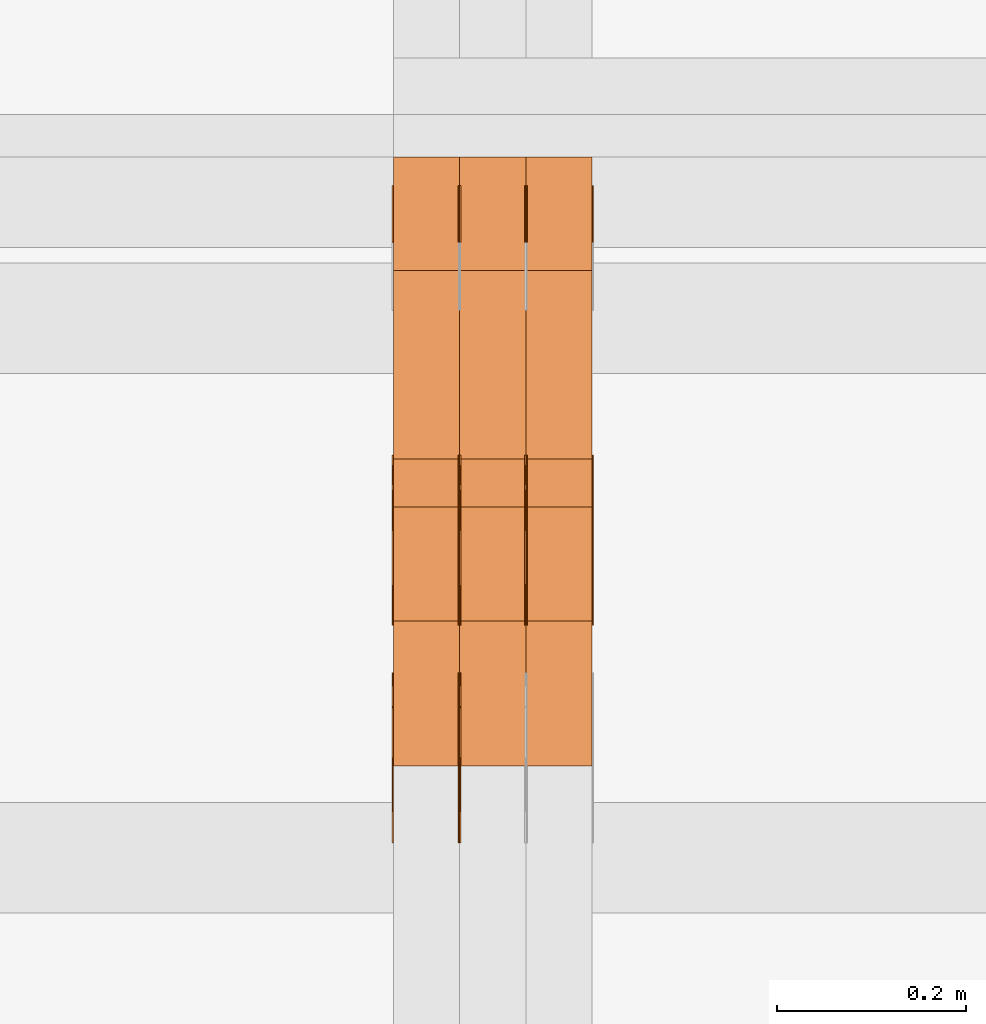
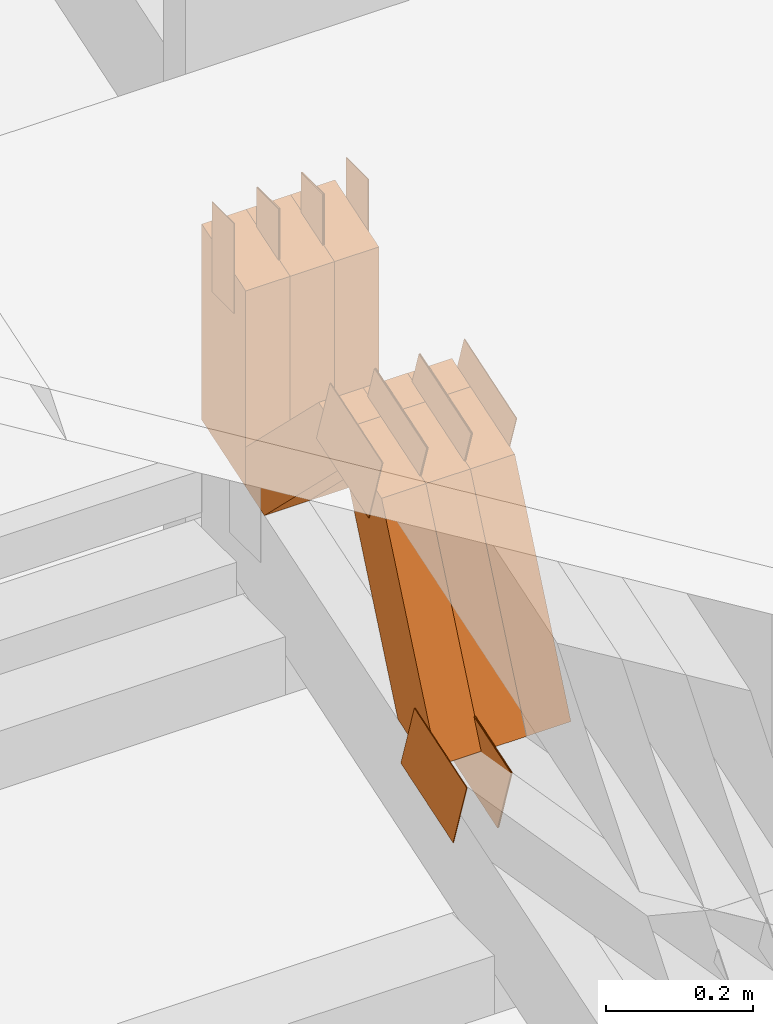
# One storey, part 160 of 385: 24 proxies.
"""IFC2X3 building model written with IfcOpenShell, lengths in millimetres."""

from ifc_helpers import new_model, entity, si_unit, converted_unit, derived_unit, direction, frame, origin, origin_2d_with_axis, place, context, subcontext, project, spatial, polyline, rectangle, outline, extrude, source, transform, mapped, material, type_object, type_shapes, element, save


model = new_model("IFC2X3")

# Units and contexts
model_context = context("Model", 3, precision=0.01, world=origin(), true_north=direction((6.12303176911189e-17, 1.0)))
body_context = subcontext(model_context, "Body", "Model", "MODEL_VIEW")
ifc_project = project(units=[si_unit("LENGTHUNIT", "METRE", prefix="MILLI"), si_unit("AREAUNIT", "SQUARE_METRE"), si_unit("VOLUMEUNIT", "CUBIC_METRE"), converted_unit("PLANEANGLEUNIT", "DEGREE", entity("IfcRatioMeasure", 0.0174532925199433), si_unit("PLANEANGLEUNIT", "RADIAN"), dimensions=[0, 0, 0, 0, 0, 0, 0]), si_unit("MASSUNIT", "GRAM", prefix="KILO"), derived_unit("MASSDENSITYUNIT", [(si_unit("MASSUNIT", "GRAM", prefix="KILO"), 1), (si_unit("LENGTHUNIT", "METRE"), -3)]), si_unit("TIMEUNIT", "SECOND"), si_unit("FREQUENCYUNIT", "HERTZ"), si_unit("THERMODYNAMICTEMPERATUREUNIT", "DEGREE_CELSIUS"), derived_unit("THERMALTRANSMITTANCEUNIT", [(si_unit("MASSUNIT", "GRAM", prefix="KILO"), 1), (si_unit("THERMODYNAMICTEMPERATUREUNIT", "KELVIN"), -1), (si_unit("TIMEUNIT", "SECOND"), -3)]), derived_unit("VOLUMETRICFLOWRATEUNIT", [(si_unit("LENGTHUNIT", "METRE"), 3), (si_unit("TIMEUNIT", "SECOND"), -1)]), si_unit("ELECTRICCURRENTUNIT", "AMPERE"), si_unit("ELECTRICVOLTAGEUNIT", "VOLT"), si_unit("POWERUNIT", "WATT"), si_unit("FORCEUNIT", "NEWTON", prefix="KILO"), si_unit("ILLUMINANCEUNIT", "LUX"), si_unit("LUMINOUSFLUXUNIT", "LUMEN"), si_unit("LUMINOUSINTENSITYUNIT", "CANDELA"), derived_unit("USERDEFINED", [(si_unit("MASSUNIT", "GRAM", prefix="KILO"), -1), (si_unit("LENGTHUNIT", "METRE"), -2), (si_unit("TIMEUNIT", "SECOND"), 3), (si_unit("LUMINOUSFLUXUNIT", "LUMEN"), 1)]), derived_unit("LINEARVELOCITYUNIT", [(si_unit("LENGTHUNIT", "METRE"), 1), (si_unit("TIMEUNIT", "SECOND"), -1)]), si_unit("PRESSUREUNIT", "PASCAL"), derived_unit("USERDEFINED", [(si_unit("LENGTHUNIT", "METRE"), -2), (si_unit("MASSUNIT", "GRAM", prefix="KILO"), 1), (si_unit("TIMEUNIT", "SECOND"), -2)])], contexts=[model_context])

# Site, building, storey
site_placement = place(None, origin())
site = spatial("IfcSite", under=ifc_project, at=site_placement, CompositionType="ELEMENT")
building_placement = place(site_placement, origin())
building = spatial("IfcBuilding", under=site, at=building_placement, CompositionType="ELEMENT")
storey_placement = place(building_placement, origin())
storey = spatial("IfcBuildingStorey", under=building, at=storey_placement, Name="Default", CompositionType="ELEMENT", Elevation=0.0)

# Proxies
ifc_material_1 = material(Name="IfcSurfaceStyle #380787")
building_element_proxy_type_1 = type_object("IfcBuildingElementProxyType", PredefinedType="NOTDEFINED", material=ifc_material_1)
shared_shape_1 = source(origin(), body_context, "Body", "SweptSolid", [
    extrude(outline(polyline([(-75.0003398116828, -59.9998507501386), (75.0003249421766, -59.9998507501386), (75.0003398116837, 59.9998507501387), (-75.0003249421775, 59.9998507501387), (-75.0003398116828, -59.9998507501386)])), frame((75.0003398116837, 60.0000773549637, 0.0), z_axis=(0.0, 0.0, 1.0), x_axis=(-1.0, 0.0, 0.0)), (0.0, 0.0, 1.0), 1.29999999999999),
])
type_shapes(building_element_proxy_type_1, [shared_shape_1])
proxy_1_placement = place(building_placement, frame((30245.0, 13054.73046875, 3417.8388671875), z_axis=(-1.0, 0.0, 0.0), x_axis=(0.0, 0.951056516295124, 0.309016994375039)))
element("IfcBuildingElementProxy", 1, at=proxy_1_placement, inside=storey, type_object=building_element_proxy_type_1, material=ifc_material_1, context=body_context, shape_type="MappedRepresentation", body=[
    mapped(shared_shape_1, transform((0.0, 0.0, 0.0), scale=1.0)),
])
ifc_material_2 = material(Name="IfcSurfaceStyle #380730")
building_element_proxy_type_2 = type_object("IfcBuildingElementProxyType", PredefinedType="NOTDEFINED", material=ifc_material_2)
shared_shape_2 = source(origin(), body_context, "Body", "SweptSolid", [
    extrude(outline(polyline([(-75.0003398116828, -59.9998507501386), (75.0003249421766, -59.9998507501386), (75.0003398116837, 59.9998507501387), (-75.0003249421775, 59.9998507501387), (-75.0003398116828, -59.9998507501386)])), frame((75.0003398116837, 60.0000773549637, 0.0), z_axis=(0.0, 0.0, 1.0), x_axis=(-1.0, 0.0, 0.0)), (0.0, 0.0, 1.0), 1.29999999999999),
])
type_shapes(building_element_proxy_type_2, [shared_shape_2])
proxy_2_placement = place(building_placement, frame((30246.3, 13054.73046875, 3417.8388671875), z_axis=(-1.0, 0.0, 0.0), x_axis=(0.0, 0.951056516295124, 0.309016994375039)))
element("IfcBuildingElementProxy", 2, at=proxy_2_placement, inside=storey, type_object=building_element_proxy_type_2, material=ifc_material_2, context=body_context, shape_type="MappedRepresentation", body=[
    mapped(shared_shape_2, transform((0.0, 0.0, 0.0), scale=1.0)),
])
ifc_material_3 = material(Name="IfcSurfaceStyle #380673")
building_element_proxy_type_3 = type_object("IfcBuildingElementProxyType", PredefinedType="NOTDEFINED", material=ifc_material_3)
shared_shape_3 = source(origin(), body_context, "Body", "SweptSolid", [
    extrude(outline(polyline([(-75.0003398116828, -59.9998507501386), (75.0003249421766, -59.9998507501386), (75.0003398116837, 59.9998507501387), (-75.0003249421775, 59.9998507501387), (-75.0003398116828, -59.9998507501386)])), frame((75.0003398116837, 60.0000773549637, 0.0), z_axis=(0.0, 0.0, 1.0), x_axis=(-1.0, 0.0, 0.0)), (0.0, 0.0, 1.0), 1.29999999999999),
])
type_shapes(building_element_proxy_type_3, [shared_shape_3])
proxy_3_placement = place(building_placement, frame((30175.0, 13054.73046875, 3417.8388671875), z_axis=(-1.0, 0.0, 0.0), x_axis=(0.0, 0.951056516295124, 0.309016994375039)))
element("IfcBuildingElementProxy", 3, at=proxy_3_placement, inside=storey, type_object=building_element_proxy_type_3, material=ifc_material_3, context=body_context, shape_type="MappedRepresentation", body=[
    mapped(shared_shape_3, transform((0.0, 0.0, 0.0), scale=1.0)),
])
ifc_material_4 = material(Name="IfcSurfaceStyle #373092")
building_element_proxy_type_4 = type_object("IfcBuildingElementProxyType", PredefinedType="NOTDEFINED", material=ifc_material_4)
shared_shape_4 = source(origin(), body_context, "Body", "SweptSolid", [
    extrude(outline(polyline([(-74.999875428623, -60.0000016373506), (74.9998605591059, -60.0000016373506), (74.9998754286239, 60.0000016373506), (-74.9998605591068, 60.0000016373506), (-74.999875428623, -60.0000016373506)])), frame((75.0002691827262, 60.0000190504561, 0.0), z_axis=(0.0, 0.0, 1.0), x_axis=(-1.0, 0.0, 0.0)), (0.0, 0.0, 1.0), 1.3),
])
type_shapes(building_element_proxy_type_4, [shared_shape_4])
proxy_4_placement = place(building_placement, frame((30386.3, 13285.0865109705, 3819.37496637467), z_axis=(-1.0, 0.0, 0.0), x_axis=(0.0, 0.951056516295154, 0.309016994374948)))
element("IfcBuildingElementProxy", 4, at=proxy_4_placement, inside=storey, type_object=building_element_proxy_type_4, material=ifc_material_4, context=body_context, shape_type="MappedRepresentation", body=[
    mapped(shared_shape_4, transform((0.0, 0.0, 0.0), scale=1.0)),
])
ifc_material_5 = material(Name="IfcSurfaceStyle #373035")
building_element_proxy_type_5 = type_object("IfcBuildingElementProxyType", PredefinedType="NOTDEFINED", material=ifc_material_5)
shared_shape_5 = source(origin(), body_context, "Body", "SweptSolid", [
    extrude(outline(polyline([(-74.999875428623, -60.0000016373506), (74.9998605591059, -60.0000016373506), (74.9998754286239, 60.0000016373506), (-74.9998605591068, 60.0000016373506), (-74.999875428623, -60.0000016373506)])), frame((75.0002691827262, 60.0000190504561, 0.0), z_axis=(0.0, 0.0, 1.0), x_axis=(-1.0, 0.0, 0.0)), (0.0, 0.0, 1.0), 1.3),
])
type_shapes(building_element_proxy_type_5, [shared_shape_5])
proxy_5_placement = place(building_placement, frame((30315.0, 13285.0865109705, 3819.37496637467), z_axis=(-1.0, 0.0, 0.0), x_axis=(0.0, 0.951056516295154, 0.309016994374948)))
element("IfcBuildingElementProxy", 5, at=proxy_5_placement, inside=storey, type_object=building_element_proxy_type_5, material=ifc_material_5, context=body_context, shape_type="MappedRepresentation", body=[
    mapped(shared_shape_5, transform((0.0, 0.0, 0.0), scale=1.0)),
])
ifc_material_6 = material(Name="IfcSurfaceStyle #372978")
building_element_proxy_type_6 = type_object("IfcBuildingElementProxyType", PredefinedType="NOTDEFINED", material=ifc_material_6)
shared_shape_6 = source(origin(), body_context, "Body", "SweptSolid", [
    extrude(outline(polyline([(-74.999875428623, -60.0000016373506), (74.9998605591059, -60.0000016373506), (74.9998754286239, 60.0000016373506), (-74.9998605591068, 60.0000016373506), (-74.999875428623, -60.0000016373506)])), frame((75.0002691827262, 60.0000190504561, 0.0), z_axis=(0.0, 0.0, 1.0), x_axis=(-1.0, 0.0, 0.0)), (0.0, 0.0, 1.0), 1.3),
])
type_shapes(building_element_proxy_type_6, [shared_shape_6])
proxy_6_placement = place(building_placement, frame((30316.3, 13285.0865109705, 3819.37496637467), z_axis=(-1.0, 0.0, 0.0), x_axis=(0.0, 0.951056516295154, 0.309016994374948)))
element("IfcBuildingElementProxy", 6, at=proxy_6_placement, inside=storey, type_object=building_element_proxy_type_6, material=ifc_material_6, context=body_context, shape_type="MappedRepresentation", body=[
    mapped(shared_shape_6, transform((0.0, 0.0, 0.0), scale=1.0)),
])
ifc_material_7 = material(Name="IfcSurfaceStyle #372921")
building_element_proxy_type_7 = type_object("IfcBuildingElementProxyType", PredefinedType="NOTDEFINED", material=ifc_material_7)
shared_shape_7 = source(origin(), body_context, "Body", "SweptSolid", [
    extrude(outline(polyline([(-74.999875428623, -60.0000016373506), (74.9998605591059, -60.0000016373506), (74.9998754286239, 60.0000016373506), (-74.9998605591068, 60.0000016373506), (-74.999875428623, -60.0000016373506)])), frame((75.0002691827262, 60.0000190504561, 0.0), z_axis=(0.0, 0.0, 1.0), x_axis=(-1.0, 0.0, 0.0)), (0.0, 0.0, 1.0), 1.29999999999999),
])
type_shapes(building_element_proxy_type_7, [shared_shape_7])
proxy_7_placement = place(building_placement, frame((30245.0, 13285.0865109705, 3819.37496637467), z_axis=(-1.0, 0.0, 0.0), x_axis=(0.0, 0.951056516295154, 0.309016994374948)))
element("IfcBuildingElementProxy", 7, at=proxy_7_placement, inside=storey, type_object=building_element_proxy_type_7, material=ifc_material_7, context=body_context, shape_type="MappedRepresentation", body=[
    mapped(shared_shape_7, transform((0.0, 0.0, 0.0), scale=1.0)),
])
ifc_material_8 = material(Name="IfcSurfaceStyle #372864")
building_element_proxy_type_8 = type_object("IfcBuildingElementProxyType", PredefinedType="NOTDEFINED", material=ifc_material_8)
shared_shape_8 = source(origin(), body_context, "Body", "SweptSolid", [
    extrude(outline(polyline([(-74.999875428623, -60.0000016373506), (74.9998605591059, -60.0000016373506), (74.9998754286239, 60.0000016373506), (-74.9998605591068, 60.0000016373506), (-74.999875428623, -60.0000016373506)])), frame((75.0002691827262, 60.0000190504561, 0.0), z_axis=(0.0, 0.0, 1.0), x_axis=(-1.0, 0.0, 0.0)), (0.0, 0.0, 1.0), 1.29999999999999),
])
type_shapes(building_element_proxy_type_8, [shared_shape_8])
proxy_8_placement = place(building_placement, frame((30246.3, 13285.0865109705, 3819.37496637467), z_axis=(-1.0, 0.0, 0.0), x_axis=(0.0, 0.951056516295154, 0.309016994374948)))
element("IfcBuildingElementProxy", 8, at=proxy_8_placement, inside=storey, type_object=building_element_proxy_type_8, material=ifc_material_8, context=body_context, shape_type="MappedRepresentation", body=[
    mapped(shared_shape_8, transform((0.0, 0.0, 0.0), scale=1.0)),
])
ifc_material_9 = material(Name="IfcSurfaceStyle #372807")
building_element_proxy_type_9 = type_object("IfcBuildingElementProxyType", PredefinedType="NOTDEFINED", material=ifc_material_9)
shared_shape_9 = source(origin(), body_context, "Body", "SweptSolid", [
    extrude(outline(polyline([(-74.999875428623, -60.0000016373506), (74.9998605591059, -60.0000016373506), (74.9998754286239, 60.0000016373506), (-74.9998605591068, 60.0000016373506), (-74.999875428623, -60.0000016373506)])), frame((75.0002691827262, 60.0000190504561, 0.0), z_axis=(0.0, 0.0, 1.0), x_axis=(-1.0, 0.0, 0.0)), (0.0, 0.0, 1.0), 1.29999999999999),
])
type_shapes(building_element_proxy_type_9, [shared_shape_9])
proxy_9_placement = place(building_placement, frame((30175.0, 13285.0865109705, 3819.37496637467), z_axis=(-1.0, 0.0, 0.0), x_axis=(0.0, 0.951056516295154, 0.309016994374948)))
element("IfcBuildingElementProxy", 9, at=proxy_9_placement, inside=storey, type_object=building_element_proxy_type_9, material=ifc_material_9, context=body_context, shape_type="MappedRepresentation", body=[
    mapped(shared_shape_9, transform((0.0, 0.0, 0.0), scale=1.0)),
])
ifc_material_10 = material(Name="IfcSurfaceStyle #372408")
building_element_proxy_type_10 = type_object("IfcBuildingElementProxyType", PredefinedType="NOTDEFINED", material=ifc_material_10)
shared_shape_10 = source(origin(), body_context, "Body", "SweptSolid", [
    extrude(rectangle(XDim=150.0, YDim=60.0, at=origin_2d_with_axis()), frame((75.0000705696166, 30.0, 0.0), z_axis=(0.0, 0.0, 1.0), x_axis=(-1.0, 0.0, 0.0)), (0.0, 0.0, 1.0), 1.3),
])
type_shapes(building_element_proxy_type_10, [shared_shape_10])
proxy_10_placement = place(building_placement, frame((30386.3, 13750.0, 3972.59919166337), z_axis=(-1.0, 0.0, 0.0), x_axis=(0.0, 0.0, -1.0)))
element("IfcBuildingElementProxy", 10, at=proxy_10_placement, inside=storey, type_object=building_element_proxy_type_10, material=ifc_material_10, context=body_context, shape_type="MappedRepresentation", body=[
    mapped(shared_shape_10, transform((0.0, 0.0, 0.0), scale=1.0)),
])
ifc_material_11 = material(Name="IfcSurfaceStyle #372351")
building_element_proxy_type_11 = type_object("IfcBuildingElementProxyType", PredefinedType="NOTDEFINED", material=ifc_material_11)
shared_shape_11 = source(origin(), body_context, "Body", "SweptSolid", [
    extrude(rectangle(XDim=150.0, YDim=60.0, at=origin_2d_with_axis()), frame((75.0000705696166, 30.0, 0.0), z_axis=(0.0, 0.0, 1.0), x_axis=(-1.0, 0.0, 0.0)), (0.0, 0.0, 1.0), 1.3),
])
type_shapes(building_element_proxy_type_11, [shared_shape_11])
proxy_11_placement = place(building_placement, frame((30315.0, 13750.0, 3972.59919166337), z_axis=(-1.0, 0.0, 0.0), x_axis=(0.0, 0.0, -1.0)))
element("IfcBuildingElementProxy", 11, at=proxy_11_placement, inside=storey, type_object=building_element_proxy_type_11, material=ifc_material_11, context=body_context, shape_type="MappedRepresentation", body=[
    mapped(shared_shape_11, transform((0.0, 0.0, 0.0), scale=1.0)),
])
ifc_material_12 = material(Name="IfcSurfaceStyle #372294")
building_element_proxy_type_12 = type_object("IfcBuildingElementProxyType", PredefinedType="NOTDEFINED", material=ifc_material_12)
shared_shape_12 = source(origin(), body_context, "Body", "SweptSolid", [
    extrude(rectangle(XDim=150.0, YDim=60.0, at=origin_2d_with_axis()), frame((75.0000705696166, 30.0, 0.0), z_axis=(0.0, 0.0, 1.0), x_axis=(-1.0, 0.0, 0.0)), (0.0, 0.0, 1.0), 1.3),
])
type_shapes(building_element_proxy_type_12, [shared_shape_12])
proxy_12_placement = place(building_placement, frame((30316.3, 13750.0, 3972.59919166337), z_axis=(-1.0, 0.0, 0.0), x_axis=(0.0, 0.0, -1.0)))
element("IfcBuildingElementProxy", 12, at=proxy_12_placement, inside=storey, type_object=building_element_proxy_type_12, material=ifc_material_12, context=body_context, shape_type="MappedRepresentation", body=[
    mapped(shared_shape_12, transform((0.0, 0.0, 0.0), scale=1.0)),
])
ifc_material_13 = material(Name="IfcSurfaceStyle #372237")
building_element_proxy_type_13 = type_object("IfcBuildingElementProxyType", PredefinedType="NOTDEFINED", material=ifc_material_13)
shared_shape_13 = source(origin(), body_context, "Body", "SweptSolid", [
    extrude(rectangle(XDim=150.0, YDim=60.0, at=origin_2d_with_axis()), frame((75.0000705696166, 30.0, 0.0), z_axis=(0.0, 0.0, 1.0), x_axis=(-1.0, 0.0, 0.0)), (0.0, 0.0, 1.0), 1.29999999999999),
])
type_shapes(building_element_proxy_type_13, [shared_shape_13])
proxy_13_placement = place(building_placement, frame((30245.0, 13750.0, 3972.59919166337), z_axis=(-1.0, 0.0, 0.0), x_axis=(0.0, 0.0, -1.0)))
element("IfcBuildingElementProxy", 13, at=proxy_13_placement, inside=storey, type_object=building_element_proxy_type_13, material=ifc_material_13, context=body_context, shape_type="MappedRepresentation", body=[
    mapped(shared_shape_13, transform((0.0, 0.0, 0.0), scale=1.0)),
])
ifc_material_14 = material(Name="IfcSurfaceStyle #372180")
building_element_proxy_type_14 = type_object("IfcBuildingElementProxyType", PredefinedType="NOTDEFINED", material=ifc_material_14)
shared_shape_14 = source(origin(), body_context, "Body", "SweptSolid", [
    extrude(rectangle(XDim=150.0, YDim=60.0, at=origin_2d_with_axis()), frame((75.0000705696166, 30.0, 0.0), z_axis=(0.0, 0.0, 1.0), x_axis=(-1.0, 0.0, 0.0)), (0.0, 0.0, 1.0), 1.29999999999999),
])
type_shapes(building_element_proxy_type_14, [shared_shape_14])
proxy_14_placement = place(building_placement, frame((30246.3, 13750.0, 3972.59919166337), z_axis=(-1.0, 0.0, 0.0), x_axis=(0.0, 0.0, -1.0)))
element("IfcBuildingElementProxy", 14, at=proxy_14_placement, inside=storey, type_object=building_element_proxy_type_14, material=ifc_material_14, context=body_context, shape_type="MappedRepresentation", body=[
    mapped(shared_shape_14, transform((0.0, 0.0, 0.0), scale=1.0)),
])
ifc_material_15 = material(Name="IfcSurfaceStyle #372123")
building_element_proxy_type_15 = type_object("IfcBuildingElementProxyType", PredefinedType="NOTDEFINED", material=ifc_material_15)
shared_shape_15 = source(origin(), body_context, "Body", "SweptSolid", [
    extrude(rectangle(XDim=150.0, YDim=60.0, at=origin_2d_with_axis()), frame((75.0000705696166, 30.0, 0.0), z_axis=(0.0, 0.0, 1.0), x_axis=(-1.0, 0.0, 0.0)), (0.0, 0.0, 1.0), 1.29999999999999),
])
type_shapes(building_element_proxy_type_15, [shared_shape_15])
proxy_15_placement = place(building_placement, frame((30175.0, 13750.0, 3972.59919166337), z_axis=(-1.0, 0.0, 0.0), x_axis=(0.0, 0.0, -1.0)))
element("IfcBuildingElementProxy", 15, at=proxy_15_placement, inside=storey, type_object=building_element_proxy_type_15, material=ifc_material_15, context=body_context, shape_type="MappedRepresentation", body=[
    mapped(shared_shape_15, transform((0.0, 0.0, 0.0), scale=1.0)),
])
ifc_material_16 = material(Name="IfcSurfaceStyle #362922")
building_element_proxy_type_16 = type_object("IfcBuildingElementProxyType", Name="T1-W49 362920", PredefinedType="NOTDEFINED", material=ifc_material_16)
shared_shape_16 = source(origin(), body_context, "Body", "SweptSolid", [
    extrude(outline(polyline([(-155.175867306415, -47.4997478409253), (152.310664695054, -47.4997478409253), (170.496756790954, -6.14570120142345e-05), (145.70957993751, 47.4998092979374), (-133.37808995724, 47.4998092979373), (-179.963044159863, -6.14570120298391e-05), (-155.175867306415, -47.4997478409253)])), frame((170.496756790954, 47.5001152140455, 0.0), z_axis=(0.0, 0.0, 1.0), x_axis=(-1.0, 0.0, 0.0)), (0.0, 0.0, 1.0), 70.0),
])
type_shapes(building_element_proxy_type_16, [shared_shape_16])
proxy_16_placement = place(building_placement, frame((30385.0, 13443.048524104, 3830.71841973934), z_axis=(-1.0, 0.0, 0.0), x_axis=(0.0, 0.713950095632063, -0.700196587357413)))
element("IfcBuildingElementProxy", 16, at=proxy_16_placement, inside=storey, type_object=building_element_proxy_type_16, material=ifc_material_16, Name="T1-W49", context=body_context, shape_type="MappedRepresentation", body=[
    mapped(shared_shape_16, transform((0.0, 0.0, 0.0), scale=1.0)),
])
ifc_material_17 = material(Name="IfcSurfaceStyle #362847")
building_element_proxy_type_17 = type_object("IfcBuildingElementProxyType", Name="T1-W49 362845", PredefinedType="NOTDEFINED", material=ifc_material_17)
shared_shape_17 = source(origin(), body_context, "Body", "SweptSolid", [
    extrude(outline(polyline([(-155.175867306415, -47.4997478409253), (152.310664695054, -47.4997478409253), (170.496756790954, -6.14570120142345e-05), (145.70957993751, 47.4998092979374), (-133.37808995724, 47.4998092979373), (-179.963044159863, -6.14570120298391e-05), (-155.175867306415, -47.4997478409253)])), frame((170.496756790954, 47.5001152140455, 0.0), z_axis=(0.0, 0.0, 1.0), x_axis=(-1.0, 0.0, 0.0)), (0.0, 0.0, 1.0), 70.0),
])
type_shapes(building_element_proxy_type_17, [shared_shape_17])
proxy_17_placement = place(building_placement, frame((30315.0, 13443.048524104, 3830.71841973934), z_axis=(-1.0, 0.0, 0.0), x_axis=(0.0, 0.713950095632063, -0.700196587357413)))
element("IfcBuildingElementProxy", 17, at=proxy_17_placement, inside=storey, type_object=building_element_proxy_type_17, material=ifc_material_17, Name="T1-W49", context=body_context, shape_type="MappedRepresentation", body=[
    mapped(shared_shape_17, transform((0.0, 0.0, 0.0), scale=1.0)),
])
ifc_material_18 = material(Name="IfcSurfaceStyle #362772")
building_element_proxy_type_18 = type_object("IfcBuildingElementProxyType", Name="T1-W49 362770", PredefinedType="NOTDEFINED", material=ifc_material_18)
shared_shape_18 = source(origin(), body_context, "Body", "SweptSolid", [
    extrude(outline(polyline([(-155.175867306415, -47.4997478409253), (152.310664695054, -47.4997478409253), (170.496756790954, -6.14570120142345e-05), (145.70957993751, 47.4998092979374), (-133.37808995724, 47.4998092979373), (-179.963044159863, -6.14570120298391e-05), (-155.175867306415, -47.4997478409253)])), frame((170.496756790954, 47.5001152140455, 0.0), z_axis=(0.0, 0.0, 1.0), x_axis=(-1.0, 0.0, 0.0)), (0.0, 0.0, 1.0), 70.0),
])
type_shapes(building_element_proxy_type_18, [shared_shape_18])
proxy_18_placement = place(building_placement, frame((30245.0, 13443.048524104, 3830.71841973934), z_axis=(-1.0, 0.0, 0.0), x_axis=(0.0, 0.713950095632063, -0.700196587357413)))
element("IfcBuildingElementProxy", 18, at=proxy_18_placement, inside=storey, type_object=building_element_proxy_type_18, material=ifc_material_18, Name="T1-W49", context=body_context, shape_type="MappedRepresentation", body=[
    mapped(shared_shape_18, transform((0.0, 0.0, 0.0), scale=1.0)),
])
ifc_material_19 = material(Name="IfcSurfaceStyle #362472")
building_element_proxy_type_19 = type_object("IfcBuildingElementProxyType", Name="T1-W1 362470", PredefinedType="NOTDEFINED", material=ifc_material_19)
shared_shape_19 = source(origin(), body_context, "Body", "SweptSolid", [
    extrude(outline(polyline([(-182.839782714844, -60.0), (143.849426269531, -60.0), (182.839660644531, 60.0), (-143.849304199219, 60.0), (-182.839782714844, -60.0)])), frame((182.839674685549, 60.0, 0.0), z_axis=(0.0, 0.0, 1.0), x_axis=(-1.0, 0.0, 0.0)), (0.0, 0.0, 1.0), 70.0),
])
type_shapes(building_element_proxy_type_19, [shared_shape_19])
proxy_19_placement = place(building_placement, frame((30385.0, 13660.0, 3551.41502502148), z_axis=(-1.0, 0.0, 0.0), x_axis=(0.0, 0.0, 1.0)))
element("IfcBuildingElementProxy", 19, at=proxy_19_placement, inside=storey, type_object=building_element_proxy_type_19, material=ifc_material_19, Name="T1-W1", context=body_context, shape_type="MappedRepresentation", body=[
    mapped(shared_shape_19, transform((0.0, 0.0, 0.0), scale=1.0)),
])
ifc_material_20 = material(Name="IfcSurfaceStyle #362415")
building_element_proxy_type_20 = type_object("IfcBuildingElementProxyType", Name="T1-W1 362413", PredefinedType="NOTDEFINED", material=ifc_material_20)
shared_shape_20 = source(origin(), body_context, "Body", "SweptSolid", [
    extrude(outline(polyline([(-182.839782714844, -60.0), (143.849426269531, -60.0), (182.839660644531, 60.0), (-143.849304199219, 60.0), (-182.839782714844, -60.0)])), frame((182.839674685549, 60.0, 0.0), z_axis=(0.0, 0.0, 1.0), x_axis=(-1.0, 0.0, 0.0)), (0.0, 0.0, 1.0), 70.0),
])
type_shapes(building_element_proxy_type_20, [shared_shape_20])
proxy_20_placement = place(building_placement, frame((30315.0, 13660.0, 3551.41502502148), z_axis=(-1.0, 0.0, 0.0), x_axis=(0.0, 0.0, 1.0)))
element("IfcBuildingElementProxy", 20, at=proxy_20_placement, inside=storey, type_object=building_element_proxy_type_20, material=ifc_material_20, Name="T1-W1", context=body_context, shape_type="MappedRepresentation", body=[
    mapped(shared_shape_20, transform((0.0, 0.0, 0.0), scale=1.0)),
])
ifc_material_21 = material(Name="IfcSurfaceStyle #362358")
building_element_proxy_type_21 = type_object("IfcBuildingElementProxyType", Name="T1-W1 362356", PredefinedType="NOTDEFINED", material=ifc_material_21)
shared_shape_21 = source(origin(), body_context, "Body", "SweptSolid", [
    extrude(outline(polyline([(-182.839782714844, -60.0), (143.849426269531, -60.0), (182.839660644531, 60.0), (-143.849304199219, 60.0), (-182.839782714844, -60.0)])), frame((182.839674685549, 60.0, 0.0), z_axis=(0.0, 0.0, 1.0), x_axis=(-1.0, 0.0, 0.0)), (0.0, 0.0, 1.0), 70.0),
])
type_shapes(building_element_proxy_type_21, [shared_shape_21])
proxy_21_placement = place(building_placement, frame((30245.0, 13660.0, 3551.41502502148), z_axis=(-1.0, 0.0, 0.0), x_axis=(0.0, 0.0, 1.0)))
element("IfcBuildingElementProxy", 21, at=proxy_21_placement, inside=storey, type_object=building_element_proxy_type_21, material=ifc_material_21, Name="T1-W1", context=body_context, shape_type="MappedRepresentation", body=[
    mapped(shared_shape_21, transform((0.0, 0.0, 0.0), scale=1.0)),
])
ifc_material_22 = material(Name="IfcSurfaceStyle #361932")
building_element_proxy_type_22 = type_object("IfcBuildingElementProxyType", Name="T1-W42 361930", PredefinedType="NOTDEFINED", material=ifc_material_22)
shared_shape_22 = source(origin(), body_context, "Body", "SweptSolid", [
    extrude(outline(polyline([(-284.837590197601, -47.4997543607933), (129.95880168156, -47.4997543607933), (171.972324990451, 0.000162623346093338), (183.717007105413, 47.4996730491203), (-200.810543579822, 47.4996730491203), (-284.837590197601, -47.4997543607933)])), frame((183.717155718752, 47.4999821655365, 0.0), z_axis=(0.0, 0.0, 1.0), x_axis=(-1.0, 0.0, 0.0)), (0.0, 0.0, 1.0), 70.0),
])
type_shapes(building_element_proxy_type_22, [shared_shape_22])
proxy_22_placement = place(building_placement, frame((30385.0, 13135.8834463264, 3404.958483022), z_axis=(-1.0, 0.0, 0.0), x_axis=(0.0, 0.398630596470292, 0.917111578575769)))
element("IfcBuildingElementProxy", 22, at=proxy_22_placement, inside=storey, type_object=building_element_proxy_type_22, material=ifc_material_22, Name="T1-W42", context=body_context, shape_type="MappedRepresentation", body=[
    mapped(shared_shape_22, transform((0.0, 0.0, 0.0), scale=1.0)),
])
ifc_material_23 = material(Name="IfcSurfaceStyle #361866")
building_element_proxy_type_23 = type_object("IfcBuildingElementProxyType", Name="T1-W42 361864", PredefinedType="NOTDEFINED", material=ifc_material_23)
shared_shape_23 = source(origin(), body_context, "Body", "SweptSolid", [
    extrude(outline(polyline([(-284.837590197601, -47.4997543607933), (129.95880168156, -47.4997543607933), (171.972324990451, 0.000162623346093338), (183.717007105413, 47.4996730491203), (-200.810543579822, 47.4996730491203), (-284.837590197601, -47.4997543607933)])), frame((183.717155718752, 47.4999821655365, 0.0), z_axis=(0.0, 0.0, 1.0), x_axis=(-1.0, 0.0, 0.0)), (0.0, 0.0, 1.0), 70.0),
])
type_shapes(building_element_proxy_type_23, [shared_shape_23])
proxy_23_placement = place(building_placement, frame((30315.0, 13135.8834463264, 3404.958483022), z_axis=(-1.0, 0.0, 0.0), x_axis=(0.0, 0.398630596470292, 0.917111578575769)))
element("IfcBuildingElementProxy", 23, at=proxy_23_placement, inside=storey, type_object=building_element_proxy_type_23, material=ifc_material_23, Name="T1-W42", context=body_context, shape_type="MappedRepresentation", body=[
    mapped(shared_shape_23, transform((0.0, 0.0, 0.0), scale=1.0)),
])
ifc_material_24 = material(Name="IfcSurfaceStyle #361800")
building_element_proxy_type_24 = type_object("IfcBuildingElementProxyType", Name="T1-W42 361798", PredefinedType="NOTDEFINED", material=ifc_material_24)
shared_shape_24 = source(origin(), body_context, "Body", "SweptSolid", [
    extrude(outline(polyline([(-284.837590197601, -47.4997543607933), (129.95880168156, -47.4997543607933), (171.972324990451, 0.000162623346093338), (183.717007105413, 47.4996730491203), (-200.810543579822, 47.4996730491203), (-284.837590197601, -47.4997543607933)])), frame((183.717155718752, 47.4999821655365, 0.0), z_axis=(0.0, 0.0, 1.0), x_axis=(-1.0, 0.0, 0.0)), (0.0, 0.0, 1.0), 70.0),
])
type_shapes(building_element_proxy_type_24, [shared_shape_24])
proxy_24_placement = place(building_placement, frame((30245.0, 13135.8834463264, 3404.958483022), z_axis=(-1.0, 0.0, 0.0), x_axis=(0.0, 0.398630596470292, 0.917111578575769)))
element("IfcBuildingElementProxy", 24, at=proxy_24_placement, inside=storey, type_object=building_element_proxy_type_24, material=ifc_material_24, Name="T1-W42", context=body_context, shape_type="MappedRepresentation", body=[
    mapped(shared_shape_24, transform((0.0, 0.0, 0.0), scale=1.0)),
])

save(model, "model.ifc")
